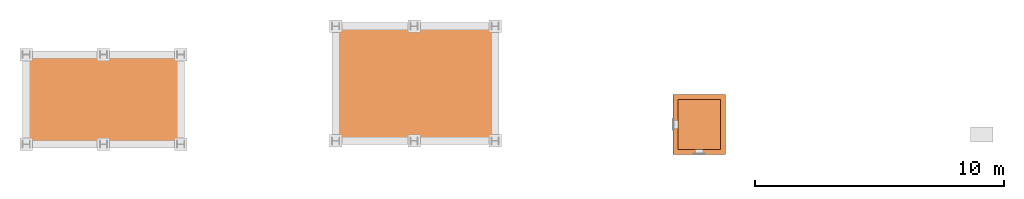
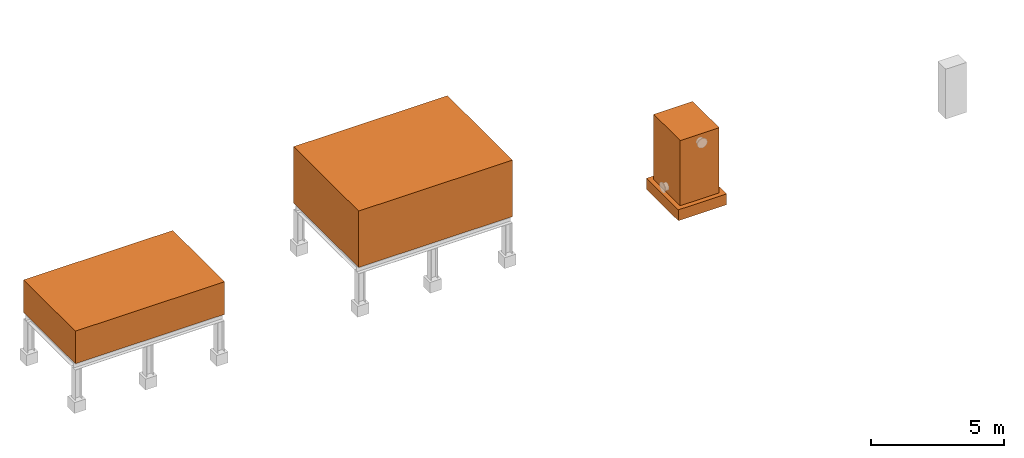
# One storey, part 3 of 6: 4 proxies.
"""IFC2X3 building model written with IfcOpenShell, lengths in millimetres."""

from ifc_helpers import new_model, entity, si_unit, converted_unit, direction, frame, origin_with_axes, origin_2d_with_axis, place, context, project, spatial, rectangle, extrude, source, transform, mapped, element, save


model = new_model("IFC2X3")

# Units and contexts
model_context = context("Model", 3, precision=1e-05, world=origin_with_axes(), true_north=direction((0.0, 1.0)))
ifc_project = project(units=[si_unit("LENGTHUNIT", "METRE", prefix="MILLI"), si_unit("AREAUNIT", "SQUARE_METRE"), si_unit("VOLUMEUNIT", "CUBIC_METRE"), converted_unit("PLANEANGLEUNIT", "DEGREE", entity("IfcPlaneAngleMeasure", 0.017453293), si_unit("PLANEANGLEUNIT", "RADIAN"), dimensions=[0, 0, 0, 0, 0, 0, 0]), si_unit("SOLIDANGLEUNIT", "STERADIAN"), si_unit("MASSUNIT", "GRAM"), si_unit("TIMEUNIT", "SECOND"), si_unit("THERMODYNAMICTEMPERATUREUNIT", "DEGREE_CELSIUS"), si_unit("LUMINOUSINTENSITYUNIT", "LUMEN")], contexts=[model_context])

# Site, building, storey
site_placement = place(None, origin_with_axes())
site = spatial("IfcSite", under=ifc_project, at=site_placement, CompositionType="ELEMENT")
building_placement = place(site_placement, origin_with_axes())
building = spatial("IfcBuilding", under=site, at=building_placement, Name="Default Building", CompositionType="ELEMENT")
storey_placement = place(building_placement, origin_with_axes())
storey = spatial("IfcBuildingStorey", under=building, at=storey_placement, Name="1FL", CompositionType="ELEMENT", Elevation=0.0)

# Proxies
shared_shape_1 = source(origin_with_axes(), model_context, "Body", "SweptSolid", [
    extrude(rectangle(XDim=6500.0, YDim=3900.0, at=origin_2d_with_axis()), origin_with_axes(), (0.0, 0.0, 1.0), 1500.0),
])
proxy_1_placement = place(storey_placement, frame((12114.826, 6271.433, 2200.0), z_axis=(0.0, 0.0, 1.0), x_axis=(1.0, 0.0, 0.0)))
element("IfcBuildingElementProxy", 1, at=proxy_1_placement, inside=storey, context=model_context, shape_type="MappedRepresentation", body=[
    mapped(shared_shape_1, transform((0.0, 0.0, 0.0))),
])
shared_shape_2 = source(origin_with_axes(), model_context, "Body", "SweptSolid", [
    extrude(rectangle(XDim=6700.0, YDim=4900.0, at=origin_2d_with_axis()), origin_with_axes(), (0.0, 0.0, 1.0), 2600.0),
])
proxy_2_placement = place(storey_placement, frame((24636.915865, 6908.017885, 2200.0), z_axis=(0.0, 0.0, 1.0), x_axis=(1.0, 0.0, 0.0)))
element("IfcBuildingElementProxy", 2, at=proxy_2_placement, inside=storey, context=model_context, shape_type="MappedRepresentation", body=[
    mapped(shared_shape_2, transform((0.0, 0.0, 0.0))),
])
shared_shape_3 = source(origin_with_axes(), model_context, "Body", "SweptSolid", [
    extrude(rectangle(XDim=2000.0, YDim=1700.0, at=origin_2d_with_axis()), frame((0.0, 0.0, 0.0), z_axis=(0.0, 0.0, 1.0), x_axis=(1.0, 3.69778549322349e-32, 0.0)), (0.0, 0.0, 1.0), 3000.0),
])
proxy_3_placement = place(storey_placement, frame((36032.096863, 5261.673737, 300.0), z_axis=(0.0, 0.0, 1.0), x_axis=(6.12303176911189e-17, 1.0, 0.0)))
element("IfcBuildingElementProxy", 3, at=proxy_3_placement, inside=storey, context=model_context, shape_type="MappedRepresentation", body=[
    mapped(shared_shape_3, transform((0.0, 0.0, 0.0))),
])
shared_shape_4 = source(origin_with_axes(), model_context, "Body", "SweptSolid", [
    extrude(rectangle(XDim=2400.0, YDim=2100.0, at=origin_2d_with_axis()), frame((0.0, 0.0, 0.0), z_axis=(0.0, 0.0, 1.0), x_axis=(1.0, 3.69778549322349e-32, 0.0)), (0.0, 0.0, 1.0), 500.0),
])
proxy_4_placement = place(storey_placement, frame((36032.096863, 5261.673737, -200.0), z_axis=(0.0, 0.0, 1.0), x_axis=(6.12303176911189e-17, 1.0, 0.0)))
element("IfcBuildingElementProxy", 4, at=proxy_4_placement, inside=storey, context=model_context, shape_type="MappedRepresentation", body=[
    mapped(shared_shape_4, transform((0.0, 0.0, 0.0))),
])

save(model, "model.ifc")
